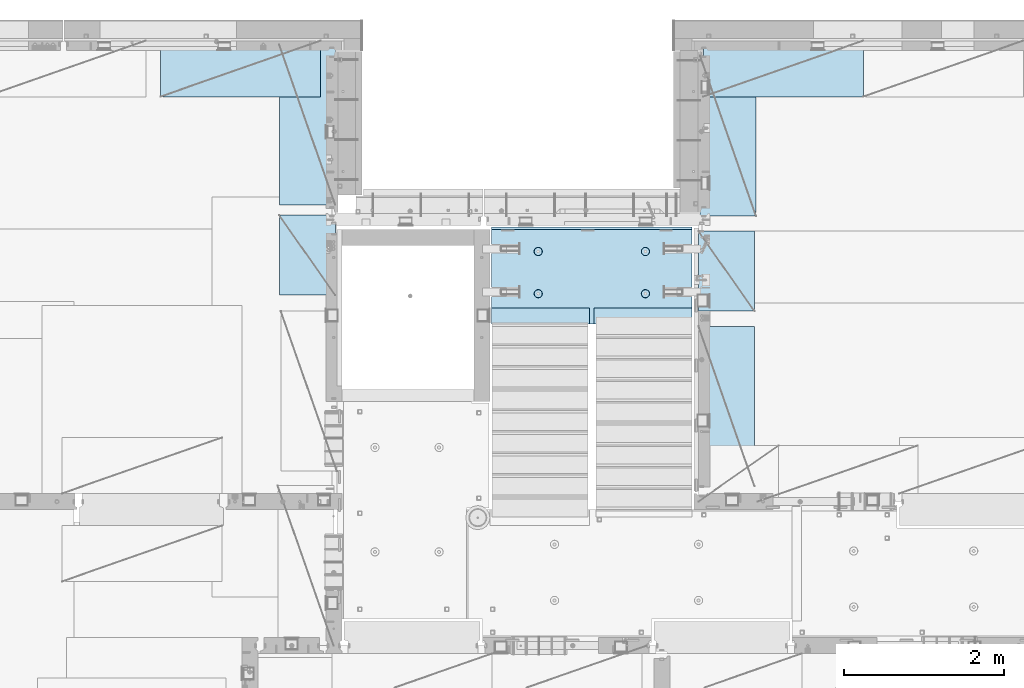
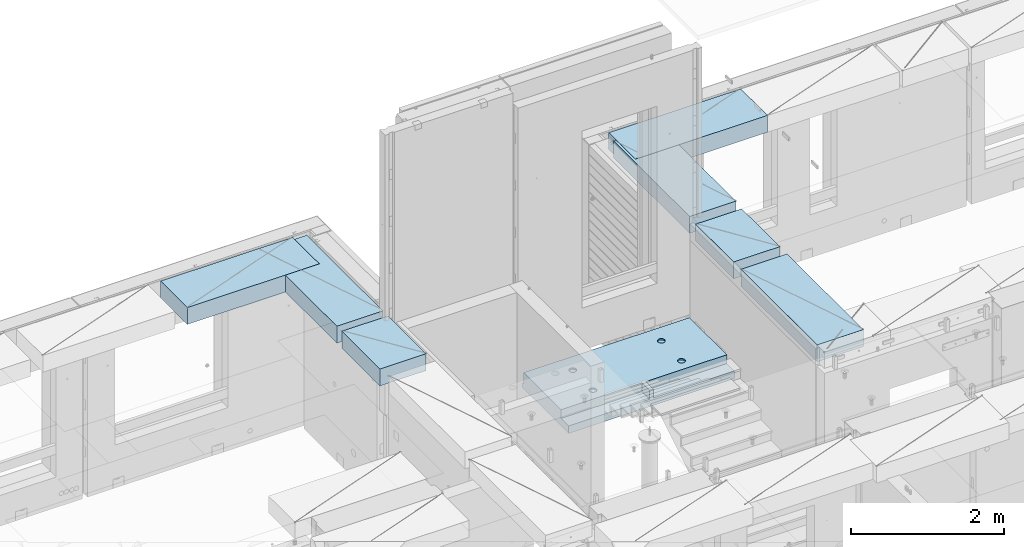
# One storey, part 208 of 352: 7 plates, 1 slab, 8 elements without a shape of their own.
"""IFC2X3 building model written with IfcOpenShell, lengths in millimetres."""

from ifc_helpers import new_model, si_unit, frame, origin_with_axes, place, context, subcontext, project, spatial, faceted_brep, material, type_object, element, aggregate, save


model = new_model("IFC2X3")

# Units and contexts
model_context = context("Model", 3, precision=1e-05, world=origin_with_axes())
body_context = subcontext(model_context, "Body", "Model", "MODEL_VIEW")
ifc_project = project(units=[si_unit("LENGTHUNIT", "METRE", prefix="MILLI"), si_unit("AREAUNIT", "SQUARE_METRE"), si_unit("VOLUMEUNIT", "CUBIC_METRE"), si_unit("MASSUNIT", "GRAM", prefix="KILO"), si_unit("TIMEUNIT", "SECOND"), si_unit("PLANEANGLEUNIT", "RADIAN"), si_unit("SOLIDANGLEUNIT", "STERADIAN"), si_unit("THERMODYNAMICTEMPERATUREUNIT", "DEGREE_CELSIUS"), si_unit("LUMINOUSINTENSITYUNIT", "LUMEN")], contexts=[model_context])

# Site, building, storey
site_placement = place(None, origin_with_axes())
site = spatial("IfcSite", under=ifc_project, at=site_placement, CompositionType="ELEMENT")
building_placement = place(site_placement, origin_with_axes())
building = spatial("IfcBuilding", under=site, at=building_placement, CompositionType="ELEMENT")
storey_placement = place(building_placement, origin_with_axes())
storey = spatial("IfcBuildingStorey", under=building, at=storey_placement, Name="6", CompositionType="ELEMENT", Elevation=0.0)

# Assembly, slab
assembly_1_placement = place(storey_placement, origin_with_axes())
assembly_1 = element("IfcElementAssembly", 1, at=assembly_1_placement, inside=storey, AssemblyPlace="NOTDEFINED", PredefinedType="REINFORCEMENT_UNIT")
ifc_material_1 = material(Name="CONCRETE/C25/30")
slab_type = type_object("IfcSlabType", PredefinedType="NOTDEFINED")
slab_placement = place(assembly_1_placement, frame((19680.000385927, 19200.0003517906, 98120.0), z_axis=(0.0, 1.0, 0.0), x_axis=(1.0, 0.0, 0.0)))
slab = element("IfcSlab", 2, at=slab_placement, type_object=slab_type, material=ifc_material_1, PredefinedType="FLOOR", context=body_context, shape_type="Brep", body=[
    faceted_brep([(1284.99890682963, -130.0, 0.0), (1284.99890682963, 10.0003972196719, 0.0), (1284.99890682963, 10.0003972196719, 200.003967285156), (1284.99890682963, -130.0, 200.003967285156), (2510.00073788432, 10.0003972196719, 200.003967285156), (2509.998046875, 10.0003972196719, 0.0), (2510.00073788432, -130.0, 200.003967285156), (2509.998046875, 60.0, 1210.00146484375), (0.0, 60.0, 1210.00146484375), (0.0, 50.0000001803419, 1180.00146538467), (2509.998046875, 50.0000001803419, 1180.00146538467), (2509.998046875, 130.0, 1210.00146484375), (0.0, 130.0, 1210.00146484375), (2509.998046875, 130.0, 0.0), (0.0, 130.0, -1.81898940354586e-12), (1225.00073788432, 10.0003972196719, 0.0), (1225.00073788432, 10.0003972196719, 200.003967285156), (-0.00109317036549328, 10.0003972196719, 200.003967285156), (0.0, 10.0003972196719, 0.0), (1225.00073788432, -130.0, 200.003967285156), (1225.00073788432, -130.0, 0.0), (0.0, -130.0, 200.003967285156), (0.0, -130.0, 1180.00146417833), (2509.998046875, -130.0, 1180.00146417833), (1940.44809334572, -110.0, 331.258272818675), (1954.3865062416, -110.0, 338.360248914683), (1965.44809334572, -110.0, 349.42183601881), (1972.55006944173, -110.0, 363.360248914683), (1974.99724362697, -110.0, 378.811098633432), (1972.55006944173, -110.0, 394.261948352181), (1965.44809334572, -110.0, 408.200361248055), (1954.3865062416, -110.0, 419.261948352181), (1940.44809334572, -110.0, 426.363924448189), (1924.99724362697, -110.0, 428.811098633432), (1909.54639390823, -110.0, 426.363924448189), (1895.60798101235, -110.0, 419.261948352181), (1884.54639390823, -110.0, 408.200361248055), (1877.44441781222, -110.0, 394.261948352181), (1874.99724362697, -110.0, 378.811098633432), (1877.44441781222, -110.0, 363.360248914683), (1884.54639390823, -110.0, 349.42183601881), (1895.60798101235, -110.0, 338.360248914683), (1909.54639390823, -110.0, 331.258272818675), (1924.99724362697, -110.0, 328.811098633432), (1974.71156152422, -130.0, 394.964259703032), (1977.2699708997, -130.0, 378.811098633432), (1967.28676833294, -130.0, 409.536236821448), (1955.72238181499, -130.0, 421.100623339393), (1941.15040469657, -130.0, 428.52541653068), (1924.99724362697, -130.0, 431.08382590616), (1908.84408255737, -130.0, 428.52541653068), (1894.27210543896, -130.0, 421.100623339393), (1882.70771892101, -130.0, 409.536236821448), (1875.28292572973, -130.0, 394.964259703032), (1872.72451635425, -130.0, 378.811098633432), (1875.28292572973, -130.0, 362.657937563832), (1882.70771892101, -130.0, 348.085960445416), (1894.27210543896, -130.0, 336.521573927472), (1908.84408255737, -130.0, 329.096780736185), (1924.99724362697, -130.0, 326.538371360704), (1941.15040469657, -130.0, 329.096780736185), (1955.72238181499, -130.0, 336.521573927472), (1967.28676833294, -130.0, 348.085960445416), (1974.71156152422, -130.0, 362.657937563832), (1940.44809334572, -110.0, 858.458272818676), (1954.3865062416, -110.0, 865.560248914684), (1965.44809334572, -110.0, 876.62183601881), (1972.55006944173, -110.0, 890.560248914684), (1974.99724362697, -110.0, 906.011098633433), (1972.55006944173, -110.0, 921.461948352182), (1965.44809334572, -110.0, 935.400361248056), (1954.3865062416, -110.0, 946.461948352182), (1940.44809334572, -110.0, 953.56392444819), (1924.99724362697, -110.0, 956.011098633433), (1909.54639390823, -110.0, 953.56392444819), (1895.60798101235, -110.0, 946.461948352182), (1884.54639390823, -110.0, 935.400361248056), (1877.44441781222, -110.0, 921.461948352182), (1874.99724362697, -110.0, 906.011098633433), (1877.44441781222, -110.0, 890.560248914684), (1884.54639390823, -110.0, 876.62183601881), (1895.60798101235, -110.0, 865.560248914684), (1909.54639390823, -110.0, 858.458272818676), (1924.99724362697, -110.0, 856.011098633433), (1974.71156152422, -130.0, 922.164259703033), (1977.2699708997, -130.0, 906.011098633433), (1967.28676833294, -130.0, 936.736236821449), (1955.72238181499, -130.0, 948.300623339394), (1941.15040469657, -130.0, 955.72541653068), (1924.99724362697, -130.0, 958.283825906161), (1908.84408255737, -130.0, 955.72541653068), (1894.27210543896, -130.0, 948.300623339394), (1882.70771892101, -130.0, 936.736236821449), (1875.28292572973, -130.0, 922.164259703033), (1872.72451635425, -130.0, 906.011098633433), (1875.28292572973, -130.0, 889.857937563833), (1882.70771892101, -130.0, 875.285960445417), (1894.27210543896, -130.0, 863.721573927472), (1908.84408255737, -130.0, 856.296780736186), (1924.99724362697, -130.0, 853.738371360705), (1941.15040469657, -130.0, 856.296780736186), (1955.72238181499, -130.0, 863.721573927472), (1967.28676833294, -130.0, 875.285960445417), (1974.71156152422, -130.0, 889.857937563833), (569.611134800252, -110.0, 426.363924448189), (555.672721904379, -110.0, 419.261948352181), (544.611134800252, -110.0, 408.200361248055), (537.509158704244, -110.0, 394.261948352181), (535.061984519001, -110.0, 378.811098633432), (537.509158704244, -110.0, 363.360248914683), (544.611134800252, -110.0, 349.42183601881), (555.672721904379, -110.0, 338.360248914683), (569.611134800252, -110.0, 331.258272818675), (585.061984519001, -110.0, 328.811098633432), (600.51283423775, -110.0, 331.258272818675), (614.451247133624, -110.0, 338.360248914683), (625.51283423775, -110.0, 349.42183601881), (632.614810333758, -110.0, 363.360248914683), (635.061984519001, -110.0, 378.811098633432), (632.614810333758, -110.0, 394.261948352181), (625.51283423775, -110.0, 408.200361248055), (614.451247133624, -110.0, 419.261948352181), (600.51283423775, -110.0, 426.363924448189), (585.061984519001, -110.0, 428.811098633432), (634.776302416249, -130.0, 394.964259703032), (637.334711791729, -130.0, 378.811098633432), (627.351509224962, -130.0, 409.536236821448), (615.787122707017, -130.0, 421.100623339393), (601.215145588601, -130.0, 428.52541653068), (585.061984519001, -130.0, 431.08382590616), (568.908823449401, -130.0, 428.52541653068), (554.336846330985, -130.0, 421.100623339393), (542.772459813041, -130.0, 409.536236821448), (535.347666621754, -130.0, 394.964259703032), (532.789257246273, -130.0, 378.811098633432), (535.347666621754, -130.0, 362.657937563832), (542.772459813041, -130.0, 348.085960445416), (554.336846330985, -130.0, 336.521573927472), (568.908823449401, -130.0, 329.096780736185), (585.061984519001, -130.0, 326.538371360704), (601.215145588601, -130.0, 329.096780736185), (615.787122707017, -130.0, 336.521573927472), (627.351509224962, -130.0, 348.085960445416), (634.776302416249, -130.0, 362.657937563832), (569.611134800252, -110.0, 953.56392444819), (555.672721904379, -110.0, 946.461948352182), (544.611134800252, -110.0, 935.400361248056), (537.509158704244, -110.0, 921.461948352182), (535.061984519001, -110.0, 906.011098633433), (537.509158704244, -110.0, 890.560248914684), (544.611134800252, -110.0, 876.62183601881), (555.672721904379, -110.0, 865.560248914684), (569.611134800252, -110.0, 858.458272818676), (585.061984519001, -110.0, 856.011098633433), (600.51283423775, -110.0, 858.458272818676), (614.451247133624, -110.0, 865.560248914684), (625.51283423775, -110.0, 876.62183601881), (632.614810333758, -110.0, 890.560248914684), (635.061984519001, -110.0, 906.011098633433), (632.614810333758, -110.0, 921.461948352182), (625.51283423775, -110.0, 935.400361248056), (614.451247133624, -110.0, 946.461948352182), (600.51283423775, -110.0, 953.56392444819), (585.061984519001, -110.0, 956.011098633433), (634.776302416249, -130.0, 922.164259703033), (637.334711791729, -130.0, 906.011098633433), (627.351509224962, -130.0, 936.736236821449), (615.787122707017, -130.0, 948.300623339394), (601.215145588601, -130.0, 955.72541653068), (585.061984519001, -130.0, 958.283825906161), (568.908823449401, -130.0, 955.72541653068), (554.336846330985, -130.0, 948.300623339394), (542.772459813041, -130.0, 936.736236821449), (535.347666621754, -130.0, 922.164259703033), (532.789257246273, -130.0, 906.011098633433), (535.347666621754, -130.0, 889.857937563833), (542.772459813041, -130.0, 875.285960445417), (554.336846330985, -130.0, 863.721573927472), (568.908823449401, -130.0, 856.296780736186), (585.061984519001, -130.0, 853.738371360705), (601.215145588601, -130.0, 856.296780736186), (615.787122707017, -130.0, 863.721573927472), (627.351509224962, -130.0, 875.285960445417), (634.776302416249, -130.0, 889.857937563833)], [[[0, 1, 2, 3]], [[4, 2, 1, 5]], [[6, 3, 2, 4]], [[7, 8, 9, 10]], [[11, 12, 8, 7]], [[11, 13, 14, 12]], [[15, 16, 17, 18]], [[19, 16, 15, 20]], [[21, 17, 16, 19]], [[22, 9, 8, 12, 14, 18, 17, 21]], [[23, 10, 9, 22]], [[5, 13, 11, 7, 10, 23, 6, 4]], [[0, 20, 15, 18, 14, 13, 5, 1]], [[24, 25, 26, 27, 28, 29, 30, 31, 32, 33, 34, 35, 36, 37, 38, 39, 40, 41, 42, 43]], [[44, 29, 28, 45]], [[46, 30, 29, 44]], [[47, 31, 30, 46]], [[48, 32, 31, 47]], [[49, 33, 32, 48]], [[50, 34, 33, 49]], [[51, 35, 34, 50]], [[52, 36, 35, 51]], [[53, 37, 36, 52]], [[54, 38, 37, 53]], [[55, 39, 38, 54]], [[56, 40, 39, 55]], [[57, 41, 40, 56]], [[58, 42, 41, 57]], [[59, 43, 42, 58]], [[60, 24, 43, 59]], [[61, 25, 24, 60]], [[62, 26, 25, 61]], [[63, 27, 26, 62]], [[45, 28, 27, 63]], [[64, 65, 66, 67, 68, 69, 70, 71, 72, 73, 74, 75, 76, 77, 78, 79, 80, 81, 82, 83]], [[84, 69, 68, 85]], [[86, 70, 69, 84]], [[87, 71, 70, 86]], [[88, 72, 71, 87]], [[89, 73, 72, 88]], [[90, 74, 73, 89]], [[91, 75, 74, 90]], [[92, 76, 75, 91]], [[93, 77, 76, 92]], [[94, 78, 77, 93]], [[95, 79, 78, 94]], [[96, 80, 79, 95]], [[97, 81, 80, 96]], [[98, 82, 81, 97]], [[99, 83, 82, 98]], [[100, 64, 83, 99]], [[101, 65, 64, 100]], [[102, 66, 65, 101]], [[103, 67, 66, 102]], [[85, 68, 67, 103]], [[104, 105, 106, 107, 108, 109, 110, 111, 112, 113, 114, 115, 116, 117, 118, 119, 120, 121, 122, 123]], [[124, 119, 118, 125]], [[126, 120, 119, 124]], [[127, 121, 120, 126]], [[128, 122, 121, 127]], [[129, 123, 122, 128]], [[130, 104, 123, 129]], [[131, 105, 104, 130]], [[132, 106, 105, 131]], [[133, 107, 106, 132]], [[134, 108, 107, 133]], [[135, 109, 108, 134]], [[136, 110, 109, 135]], [[137, 111, 110, 136]], [[138, 112, 111, 137]], [[139, 113, 112, 138]], [[140, 114, 113, 139]], [[141, 115, 114, 140]], [[142, 116, 115, 141]], [[143, 117, 116, 142]], [[125, 118, 117, 143]], [[144, 145, 146, 147, 148, 149, 150, 151, 152, 153, 154, 155, 156, 157, 158, 159, 160, 161, 162, 163]], [[164, 159, 158, 165]], [[166, 160, 159, 164]], [[167, 161, 160, 166]], [[168, 162, 161, 167]], [[169, 163, 162, 168]], [[170, 144, 163, 169]], [[171, 145, 144, 170]], [[172, 146, 145, 171]], [[173, 147, 146, 172]], [[174, 148, 147, 173]], [[175, 149, 148, 174]], [[176, 150, 149, 175]], [[177, 151, 150, 176]], [[178, 152, 151, 177]], [[179, 153, 152, 178]], [[180, 154, 153, 179]], [[181, 155, 154, 180]], [[182, 156, 155, 181]], [[183, 157, 156, 182]], [[165, 158, 157, 183]], [[23, 22, 21, 19, 20, 0, 3, 6], [182, 181, 180, 179, 178, 177, 176, 175, 174, 173, 172, 171, 170, 169, 168, 167, 166, 164, 165, 183], [142, 141, 140, 139, 138, 137, 136, 135, 134, 133, 132, 131, 130, 129, 128, 127, 126, 124, 125, 143], [102, 101, 100, 99, 98, 97, 96, 95, 94, 93, 92, 91, 90, 89, 88, 87, 86, 84, 85, 103], [62, 61, 60, 59, 58, 57, 56, 55, 54, 53, 52, 51, 50, 49, 48, 47, 46, 44, 45, 63]]]),
])
aggregate(assembly_1, [slab])

# Assembly, plate
assembly_2_placement = place(storey_placement, origin_with_axes())
assembly_2 = element("IfcElementAssembly", 3, at=assembly_2_placement, inside=storey, Name="Steel Assembly", AssemblyPlace="NOTDEFINED", PredefinedType="NOTDEFINED")
ifc_material_2 = material()
plate_type = type_object("IfcPlateType", PredefinedType="NOTDEFINED")
plate_1_placement = place(assembly_2_placement, frame((24330.0, 22740.0001220703, 99595.3), z_axis=(0.0, -1.0, 0.0), x_axis=(-1.0, 3.00000001838171e-08, 0.0)))
plate_1 = element("IfcPlate", 4, at=plate_1_placement, type_object=plate_type, material=ifc_material_2, Name="RE1", context=body_context, shape_type="Brep", body=[
    faceted_brep([(1.81898940354586e-12, -135.0, 1.81898940354586e-12), (0.0, -135.0, 699.999999999996), (0.0, 135.0, 699.999999999996), (1.81898940354586e-12, 135.0, 1.81898940354586e-12), (1999.99951171875, -135.0, 699.999999999993), (1999.99951171875, 135.0, 699.999999999993), (2000.0, -135.0, -3.63797880709171e-12), (2000.0, 135.0, -3.63797880709171e-12)], [[[0, 1, 2, 3]], [[1, 4, 5, 2]], [[4, 6, 7, 5]], [[6, 0, 3, 7]], [[5, 7, 3, 2]], [[6, 4, 1, 0]]]),
])
aggregate(assembly_2, [plate_1])

assembly_3_placement = place(storey_placement, origin_with_axes())
assembly_3 = element("IfcElementAssembly", 5, at=assembly_3_placement, inside=storey, Name="Steel Assembly", AssemblyPlace="NOTDEFINED", PredefinedType="NOTDEFINED")
plate_2_placement = place(assembly_3_placement, frame((17730.0001220703, 20690.0, 99595.3), z_axis=(-1.0, 3.00000001838171e-08, 0.0), x_axis=(0.0, 1.0, 0.0)))
plate_2 = element("IfcPlate", 6, at=plate_2_placement, type_object=plate_type, material=ifc_material_2, Name="RE1", context=body_context, shape_type="Brep", body=[
    faceted_brep([(1.81898940354586e-12, -135.0, 1.81898940354586e-12), (0.0, -135.0, 699.999999999996), (0.0, 135.0, 699.999999999996), (1.81898940354586e-12, 135.0, 1.81898940354586e-12), (1999.99951171875, -135.0, 699.999999999993), (1999.99951171875, 135.0, 699.999999999993), (2000.0, -135.0, -3.63797880709171e-12), (2000.0, 135.0, -3.63797880709171e-12)], [[[0, 1, 2, 3]], [[1, 4, 5, 2]], [[4, 6, 7, 5]], [[6, 0, 3, 7]], [[5, 7, 3, 2]], [[6, 4, 1, 0]]]),
])
aggregate(assembly_3, [plate_2])

assembly_4_placement = place(storey_placement, origin_with_axes())
assembly_4 = element("IfcElementAssembly", 7, at=assembly_4_placement, inside=storey, Name="Steel Assembly", AssemblyPlace="NOTDEFINED", PredefinedType="NOTDEFINED")
plate_3_placement = place(assembly_4_placement, frame((22269.9998779297, 19170.0, 99595.3), z_axis=(1.0, 0.0, 0.0), x_axis=(0.0, -1.0, 0.0)))
plate_3 = element("IfcPlate", 8, at=plate_3_placement, type_object=plate_type, material=ifc_material_2, Name="RE1", context=body_context, shape_type="Brep", body=[
    faceted_brep([(1.81898940354586e-12, -135.0, 1.81898940354586e-12), (0.0, -135.0, 699.999999999996), (0.0, 135.0, 699.999999999996), (1.81898940354586e-12, 135.0, 1.81898940354586e-12), (1999.99951171875, -135.0, 699.999999999993), (1999.99951171875, 135.0, 699.999999999993), (2000.0, -135.0, -3.63797880709171e-12), (2000.0, 135.0, -3.63797880709171e-12)], [[[0, 1, 2, 3]], [[1, 4, 5, 2]], [[4, 6, 7, 5]], [[6, 0, 3, 7]], [[5, 7, 3, 2]], [[6, 4, 1, 0]]]),
])
aggregate(assembly_4, [plate_3])

assembly_5_placement = place(storey_placement, origin_with_axes())
assembly_5 = element("IfcElementAssembly", 9, at=assembly_5_placement, inside=storey, Name="Steel Assembly", AssemblyPlace="NOTDEFINED", PredefinedType="NOTDEFINED")
plate_4_placement = place(assembly_5_placement, frame((22289.9998779297, 22550.0, 99595.3), z_axis=(1.0, 0.0, 0.0), x_axis=(0.0, -1.0, 0.0)))
plate_4 = element("IfcPlate", 10, at=plate_4_placement, type_object=plate_type, material=ifc_material_2, Name="RE1", context=body_context, shape_type="Brep", body=[
    faceted_brep([(1.81898940354586e-12, -135.0, 1.81898940354586e-12), (0.0, -135.0, 699.999999999996), (0.0, 135.0, 699.999999999996), (1.81898940354586e-12, 135.0, 1.81898940354586e-12), (1999.99951171875, -135.0, 699.999999999993), (1999.99951171875, 135.0, 699.999999999993), (2000.0, -135.0, -3.63797880709171e-12), (2000.0, 135.0, -3.63797880709171e-12)], [[[0, 1, 2, 3]], [[1, 4, 5, 2]], [[4, 6, 7, 5]], [[6, 0, 3, 7]], [[5, 7, 3, 2]], [[6, 4, 1, 0]]]),
])
aggregate(assembly_5, [plate_4])

assembly_6_placement = place(storey_placement, origin_with_axes())
assembly_6 = element("IfcElementAssembly", 11, at=assembly_6_placement, inside=storey, Name="Steel Assembly", AssemblyPlace="NOTDEFINED", PredefinedType="NOTDEFINED")
plate_5_placement = place(assembly_6_placement, frame((22269.9999999293, 20360.0, 99595.3), z_axis=(1.0, 0.0, 0.0), x_axis=(0.0, -1.0, 0.0)))
plate_5 = element("IfcPlate", 12, at=plate_5_placement, type_object=plate_type, material=ifc_material_2, Name="RE1_1/2", context=body_context, shape_type="Brep", body=[
    faceted_brep([(1.81898940354586e-12, -135.0, 1.81898940354586e-12), (0.0, -135.0, 699.999999999996), (0.0, 135.0, 699.999999999996), (1.81898940354586e-12, 135.0, 1.81898940354586e-12), (999.99951171875, -135.0, 700.0), (999.99951171875, 135.0, 700.0), (1000.0, -135.0, 0.0), (1000.0, 135.0, 0.0)], [[[0, 1, 2, 3]], [[1, 4, 5, 2]], [[4, 6, 7, 5]], [[6, 0, 3, 7]], [[5, 7, 3, 2]], [[6, 4, 1, 0]]]),
])
aggregate(assembly_6, [plate_5])

assembly_7_placement = place(storey_placement, origin_with_axes())
assembly_7 = element("IfcElementAssembly", 13, at=assembly_7_placement, inside=storey, Name="Steel Assembly", AssemblyPlace="NOTDEFINED", PredefinedType="NOTDEFINED")
plate_6_placement = place(assembly_7_placement, frame((17730.0000000707, 19560.0, 99595.3), z_axis=(-1.0, 3.00000001838171e-08, 0.0), x_axis=(0.0, 1.0, 0.0)))
plate_6 = element("IfcPlate", 14, at=plate_6_placement, type_object=plate_type, material=ifc_material_2, Name="RE1_1/2", context=body_context, shape_type="Brep", body=[
    faceted_brep([(1.81898940354586e-12, -135.0, 1.81898940354586e-12), (0.0, -135.0, 699.999999999996), (0.0, 135.0, 699.999999999996), (1.81898940354586e-12, 135.0, 1.81898940354586e-12), (999.99951171875, -135.0, 700.0), (999.99951171875, 135.0, 700.0), (1000.0, -135.0, 0.0), (1000.0, 135.0, 0.0)], [[[0, 1, 2, 3]], [[1, 4, 5, 2]], [[4, 6, 7, 5]], [[6, 0, 3, 7]], [[5, 7, 3, 2]], [[6, 4, 1, 0]]]),
])
aggregate(assembly_7, [plate_6])

assembly_8_placement = place(storey_placement, origin_with_axes())
assembly_8 = element("IfcElementAssembly", 15, at=assembly_8_placement, inside=storey, Name="Steel Assembly", AssemblyPlace="NOTDEFINED", PredefinedType="NOTDEFINED")
plate_7_placement = place(assembly_8_placement, frame((17545.0, 22740.0001220703, 99595.3), z_axis=(0.0, -1.0, 0.0), x_axis=(-1.0, 3.00000001838171e-08, 0.0)))
plate_7 = element("IfcPlate", 16, at=plate_7_placement, type_object=plate_type, material=ifc_material_2, Name="RE1", context=body_context, shape_type="Brep", body=[
    faceted_brep([(1.81898940354586e-12, -135.0, 1.81898940354586e-12), (0.0, -135.0, 699.999999999996), (0.0, 135.0, 699.999999999996), (1.81898940354586e-12, 135.0, 1.81898940354586e-12), (1999.99951171875, -135.0, 699.999999999993), (1999.99951171875, 135.0, 699.999999999993), (2000.0, -135.0, -3.63797880709171e-12), (2000.0, 135.0, -3.63797880709171e-12)], [[[0, 1, 2, 3]], [[1, 4, 5, 2]], [[4, 6, 7, 5]], [[6, 0, 3, 7]], [[5, 7, 3, 2]], [[6, 4, 1, 0]]]),
])
aggregate(assembly_8, [plate_7])

save(model, "model.ifc")
